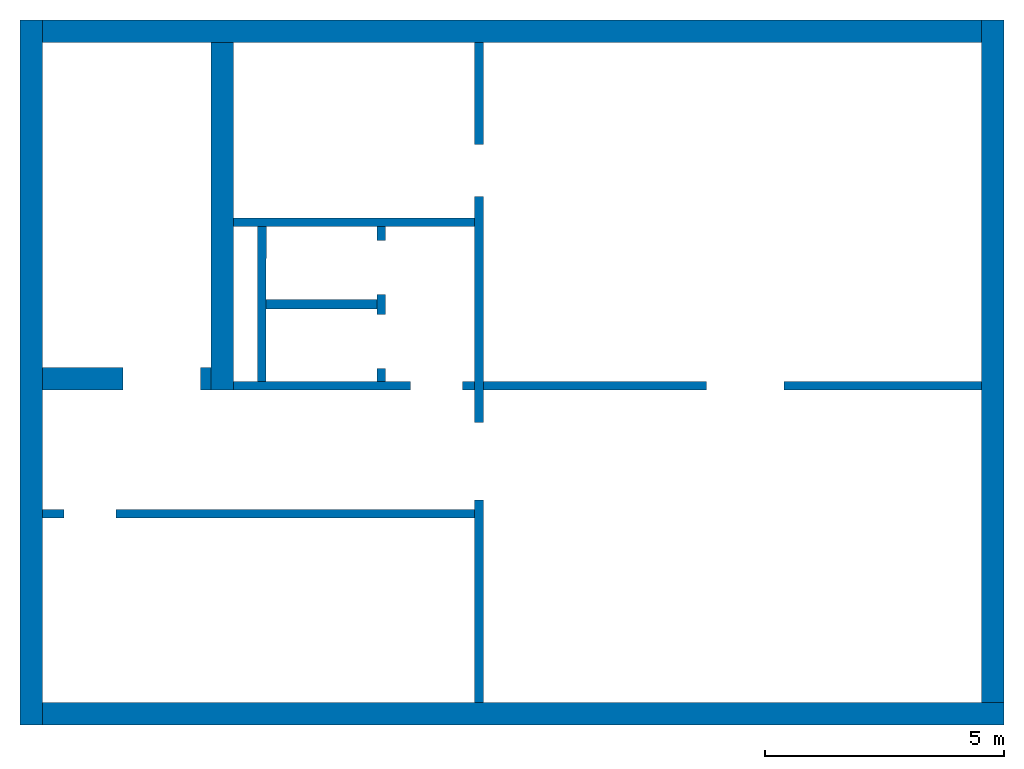
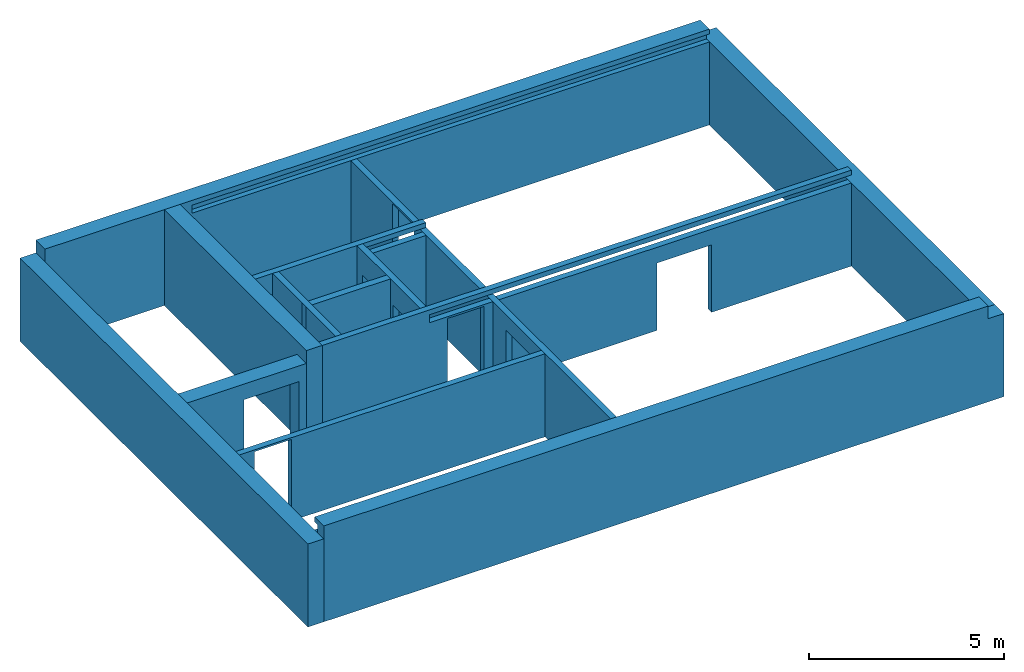
# One storey: 13 walls, 8 openings.
"""IFC4 building model written with IfcOpenShell, lengths in metres."""

from ifc_helpers import new_model, entity, si_unit, converted_unit, derived_unit, direction, frame, origin_with_axes, place, context, subcontext, project, spatial, polygons, material, type_object, element, save


model = new_model("IFC4")

# Units and contexts
model_context = context("Model", 3, precision=1e-05, world=origin_with_axes(), true_north=direction((0.0, 1.0)))
body_context = subcontext(model_context, "Body", "Model", "MODEL_VIEW")
ifc_project = project(units=[si_unit("LENGTHUNIT", "METRE"), si_unit("AREAUNIT", "SQUARE_METRE"), si_unit("VOLUMEUNIT", "CUBIC_METRE"), converted_unit("PLANEANGLEUNIT", "DEGREE", entity("IfcPlaneAngleMeasure", 0.0174532925199433), si_unit("PLANEANGLEUNIT", "RADIAN"), dimensions=[0, 0, 0, 0, 0, 0, 0]), converted_unit("TIMEUNIT", "Year", entity("IfcTimeMeasure", 31557600.0), si_unit("TIMEUNIT", "SECOND"), dimensions=[0, 0, 1, 0, 0, 0, 0]), si_unit("MASSUNIT", "GRAM", prefix="KILO"), si_unit("THERMODYNAMICTEMPERATUREUNIT", "DEGREE_CELSIUS"), si_unit("LUMINOUSINTENSITYUNIT", "LUMEN"), si_unit("ENERGYUNIT", "JOULE", prefix="MEGA"), derived_unit("THERMALCONDUCTANCEUNIT", [(si_unit("POWERUNIT", "WATT"), 1), (si_unit("LENGTHUNIT", "METRE"), -1), (si_unit("THERMODYNAMICTEMPERATUREUNIT", "KELVIN"), -1)]), derived_unit("SPECIFICHEATCAPACITYUNIT", [(si_unit("ENERGYUNIT", "JOULE"), 1), (si_unit("MASSUNIT", "GRAM", prefix="KILO"), -1), (si_unit("THERMODYNAMICTEMPERATUREUNIT", "KELVIN"), -1)]), derived_unit("MASSDENSITYUNIT", [(si_unit("MASSUNIT", "GRAM", prefix="KILO"), 1), (si_unit("VOLUMEUNIT", "CUBIC_METRE"), -1)])], contexts=[model_context])

# Site, building, storey
site_placement = place(None, origin_with_axes())
site = spatial("IfcSite", under=ifc_project, at=site_placement, CompositionType="ELEMENT")
building_placement = place(None, origin_with_axes())
building = spatial("IfcBuilding", under=site, at=building_placement, CompositionType="ELEMENT")
storey_placement = place(None, frame((0.0, 0.0, -3.0), z_axis=(0.0, 0.0, 1.0), x_axis=(1.0, 0.0, 0.0)))
storey = spatial("IfcBuildingStorey", under=building, at=storey_placement, Name="UG", CompositionType="ELEMENT", Elevation=-3.0)

# Wall, opening
ifc_material = material(Name="Stahlbeton")
wall_type_1 = type_object("IfcWallType", Name="Stahlbeton 180", PredefinedType="NOTDEFINED")
wall_1_placement = place(None, frame((33.505, 4.55499994546755, -3.0), z_axis=(0.0, 0.0, 1.0), x_axis=(-1.0, 0.0, 0.0)))
wall_1 = element("IfcWall", 1, at=wall_1_placement, inside=storey, type_object=wall_type_1, material=ifc_material, Name="Wand-003", PredefinedType="NOTDEFINED", context=body_context, shape_type="Tessellation", body=[
    polygons([(8.59699999999999, 0.0, 2.545), (8.59699999999999, 0.0, 0.0), (9.047, 0.0, 0.0), (9.047, 0.0, 2.6), (0.0, 0.0, 2.6), (0.0, 0.0, 0.0), (7.507, 0.0, 0.0), (7.507, 0.0, 2.545), (8.59699999999999, 0.18, 2.545), (8.59699999999999, 0.18, 0.0), (9.047, 0.18, 0.0), (9.047, 0.18, 2.6), (0.0, 0.180000000000001, 2.6), (0.0, 0.18, 0.0), (7.507, 0.18, 0.0), (7.507, 0.18, 2.545)], [[[1, 2, 3, 4, 5, 6, 7, 8]], [[2, 1, 9, 10]], [[2, 10, 11, 3]], [[11, 12, 4, 3]], [[12, 13, 5, 4]], [[14, 6, 5, 13]], [[15, 7, 6, 14]], [[8, 7, 15, 16]], [[1, 8, 16, 9]], [[16, 15, 14, 13, 12, 11, 10, 9]]], closed=True),
])
opening_1_placement = place(wall_1_placement, frame((8.052, 0.0, 0.0), z_axis=(0.0, 0.0, 1.0), x_axis=(1.0, 0.0, 0.0)))
element("IfcOpeningElement", 2, at=opening_1_placement, cuts=wall_1, context=body_context, identifier="Reference", shape_type="Tessellation", body=[
    polygons([(-0.544999999999998, -0.00100000000000033, 2.545), (-0.544999999999998, -0.00100000000000033, 0.0), (0.544999999999998, -0.00100000000000033, 0.0), (0.544999999999998, -0.00100000000000033, 2.545), (-0.544999999999998, 0.181, 2.545), (-0.544999999999998, 0.181, 0.0), (0.544999999999998, 0.181, 0.0), (0.544999999999998, 0.181, 2.545)], [[[1, 2, 3, 4]], [[5, 6, 2, 1]], [[6, 7, 3, 2]], [[7, 8, 4, 3]], [[8, 5, 1, 4]], [[7, 6, 5, 8]]], closed=True),
])

# Wall, openings
wall_2_placement = place(None, frame((27.988, 7.05499994546755, -3.0), z_axis=(0.0, 0.0, 1.0), x_axis=(1.0, 0.0, 0.0)))
wall_2 = element("IfcWall", 3, at=wall_2_placement, inside=storey, type_object=wall_type_1, material=ifc_material, Name="Wand-001", PredefinedType="NOTDEFINED", context=body_context, shape_type="Tessellation", body=[
    polygons([(10.370657642847, 0.18, 2.11), (10.370657642847, 0.18, 0.0), (5.69699999999999, 0.18, 0.0), (5.69699999999999, 0.180000000000002, 2.6), (8.20499999999999, 0.180000000000002, 2.6), (16.126, 0.180000000000001, 2.6), (16.126, 0.180000000000001, 0.0), (11.990657642847, 0.180000000000001, 0.0), (11.990657642847, 0.180000000000001, 2.11), (10.370657642847, 0.0, 2.11), (10.370657642847, 0.0, 0.0), (5.69699999999999, 0.0, 0.0), (5.69699999999999, 0.0, 2.6), (16.126, 0.0, 2.6), (16.126, 0.0, 0.0), (11.990657642847, 0.0, 0.0), (11.990657642847, 0.0, 2.11)], [[[1, 2, 3, 4, 5, 6, 7, 8, 9]], [[2, 1, 10, 11]], [[2, 11, 12, 3]], [[13, 4, 3, 12]], [[4, 13, 14, 6, 5]], [[6, 14, 15, 7]], [[16, 8, 7, 15]], [[9, 8, 16, 17]], [[1, 9, 17, 10]], [[17, 16, 15, 14, 13, 12, 11, 10]]], closed=True),
    polygons([(4.17199999999999, 0.18, 2.545), (4.17199999999999, 0.18, 0.0), (0.469999999999999, 0.18, 0.0), (0.469999999999999, 0.180000000000001, 3.0), (16.126, 0.180000000000001, 3.0), (16.126, 0.180000000000001, 2.85), (8.20499999999999, 0.180000000000002, 2.85), (5.69699999999999, 0.180000000000002, 2.85), (3.65000002908709, 0.18, 2.85), (3.65000002908709, 0.18, 2.6), (5.51699999999999, 0.18, 2.6), (5.51699999999999, 0.18, 0.0), (5.262, 0.18, 0.0), (5.262, 0.18, 2.545), (4.17199999999999, 1.29097926127031e-07, 2.545), (4.17199999999999, 0.0, 0.0), (0.469999999999999, 0.0, 0.0), (0.469999999999999, 0.0, 2.6), (0.469999999999999, 0.0, 3.0), (16.126, 0.0, 3.0), (16.126, 0.0, 2.85), (3.65000002908709, 1.29097926127031e-07, 2.85), (3.65000002908709, 1.29097926127031e-07, 2.6), (5.51699999999999, 0.0, 2.6), (5.51699999999999, 0.0, 0.0), (5.262, 0.0, 0.0), (5.262, 1.29097926127031e-07, 2.545)], [[[1, 2, 3, 4, 5, 6, 7, 8, 9, 10, 11, 12, 13, 14]], [[2, 1, 15, 16]], [[2, 16, 17, 3]], [[3, 17, 18, 19, 4]], [[5, 4, 19, 20]], [[21, 6, 5, 20]], [[6, 21, 22, 9, 8, 7]], [[10, 9, 22, 23]], [[24, 11, 10, 23]], [[11, 24, 25, 12]], [[26, 13, 12, 25]], [[14, 13, 26, 27]], [[1, 14, 27, 15]], [[27, 26, 25, 24, 23, 22, 21, 20, 19, 18, 17, 16, 15]]], closed=True),
])
opening_2_placement = place(wall_2_placement, frame((4.717, 0.0, 0.0), z_axis=(0.0, 0.0, 1.0), x_axis=(1.0, 0.0, 0.0)))
element("IfcOpeningElement", 4, at=opening_2_placement, cuts=wall_2, context=body_context, identifier="Reference", shape_type="Tessellation", body=[
    polygons([(-0.545000000000002, -0.00100000000000033, 2.545), (-0.545000000000002, -0.00100000000000033, 0.0), (0.545000000000002, -0.00100000000000033, 0.0), (0.545000000000002, -0.00100000000000033, 2.545), (-0.545000000000002, 0.181, 2.545), (-0.545000000000002, 0.181, 0.0), (0.545000000000002, 0.181, 0.0), (0.545000000000002, 0.181, 2.545)], [[[1, 2, 3, 4]], [[5, 6, 2, 1]], [[6, 7, 3, 2]], [[7, 8, 4, 3]], [[8, 5, 1, 4]], [[7, 6, 5, 8]]], closed=True),
])
opening_3_placement = place(wall_2_placement, frame((11.180657642847, 0.0, 0.0), z_axis=(0.0, 0.0, 1.0), x_axis=(1.0, 0.0, 0.0)))
element("IfcOpeningElement", 5, at=opening_3_placement, cuts=wall_2, context=body_context, identifier="Reference", shape_type="Tessellation", body=[
    polygons([(0.810000000000002, 0.181000000000002, 2.11), (0.810000000000002, 0.181000000000002, 0.0), (-0.810000000000002, 0.181000000000002, 0.0), (-0.810000000000002, 0.181000000000003, 2.11), (0.810000000000002, -0.00100000000000478, 2.11), (0.810000000000002, -0.00100000000000478, 0.0), (-0.810000000000002, -0.00100000000000478, 0.0), (-0.810000000000002, -0.00100000000000389, 2.11)], [[[1, 2, 3, 4]], [[5, 6, 2, 1]], [[6, 7, 3, 2]], [[7, 8, 4, 3]], [[8, 5, 1, 4]], [[7, 6, 5, 8]]], closed=True),
])

# Wall
wall_3_placement = place(None, frame((29.1377045594425, 7.05499994546755, -3.0), z_axis=(0.0, 0.0, 1.0), x_axis=(0.00164133421967425, 0.999998653010083, 0.0)))
element("IfcWall", 6, at=wall_3_placement, inside=storey, type_object=wall_type_1, material=ifc_material, Name="Wand-001", PredefinedType="NOTDEFINED", context=body_context, shape_type="Tessellation", body=[
    polygons([(0.179704801901014, 0.18, 0.0), (3.41970916615423, 0.180000000000007, 0.0), (3.42000460671172, 0.0, 0.0), (0.180000242458512, 0.0, 0.0), (0.179704801901014, 0.18, 3.0), (3.41970916615423, 0.180000000000007, 3.0), (3.42000460671172, 0.0, 3.0), (0.180000242458512, 0.0, 3.0)], [[[1, 2, 3, 4]], [[5, 6, 2, 1]], [[7, 3, 2, 6]], [[4, 3, 7, 8]], [[8, 5, 1, 4]], [[8, 7, 6, 5]]], closed=True),
])

# Wall, openings
wall_4_placement = place(None, frame((33.505, 14.3318657372406, -3.0), z_axis=(0.0, 0.0, 1.0), x_axis=(0.0, -1.0, 0.0)))
wall_4 = element("IfcWall", 7, at=wall_4_placement, inside=storey, type_object=wall_type_1, material=ifc_material, Name="Wand-001", PredefinedType="NOTDEFINED", context=body_context, shape_type="Tessellation", body=[
    polygons([(3.22686579177299, 0.18, 0.0), (3.22686579177299, 0.18, 2.545), (2.13686579177299, 0.18, 2.545), (2.13686579177299, 0.18, 0.0), (0.0, 0.18, 0.0), (0.0, 0.18, 2.6), (13.8118657372406, 0.18, 2.6), (13.8118657372406, 0.18, 0.0), (9.57686579177299, 0.18, 0.0), (9.57686579177299, 0.18, 2.11), (7.95686579177299, 0.18, 2.11), (7.95686579177299, 0.18, 0.0), (3.22686579177299, 0.0, 0.0), (3.22686579177299, 0.0, 2.545), (2.13686579177299, 0.0, 2.545), (2.13686579177299, 0.0, 0.0), (0.0, 0.0, 0.0), (0.0, 0.0, 2.6), (13.8118657372406, 0.0, 2.6), (13.8118657372406, 0.0, 0.0), (9.57686579177299, 0.0, 0.0), (9.57686579177299, 0.0, 2.11), (7.95686579177299, 0.0, 2.11), (7.95686579177299, 0.0, 0.0)], [[[1, 2, 3, 4, 5, 6, 7, 8, 9, 10, 11, 12]], [[2, 1, 13, 14]], [[3, 2, 14, 15]], [[4, 3, 15, 16]], [[4, 16, 17, 5]], [[17, 18, 6, 5]], [[6, 18, 19, 7]], [[7, 19, 20, 8]], [[9, 8, 20, 21]], [[9, 21, 22, 10]], [[10, 22, 23, 11]], [[11, 23, 24, 12]], [[13, 1, 12, 24]], [[14, 13, 24, 23, 22, 21, 20, 19, 18, 17, 16, 15]]], closed=True),
])
opening_4_placement = place(wall_4_placement, frame((2.68186579177299, 0.0, 0.0), z_axis=(0.0, 0.0, 1.0), x_axis=(1.0, 0.0, 0.0)))
element("IfcOpeningElement", 8, at=opening_4_placement, cuts=wall_4, context=body_context, identifier="Reference", shape_type="Tessellation", body=[
    polygons([(-0.545, -0.000999999999997669, 2.545), (-0.545, -0.000999999999997669, 0.0), (0.545, -0.000999999999997669, 0.0), (0.545, -0.000999999999997669, 2.545), (-0.545, 0.180999999999997, 2.545), (-0.545, 0.180999999999997, 0.0), (0.545, 0.180999999999997, 0.0), (0.545, 0.180999999999997, 2.545)], [[[1, 2, 3, 4]], [[5, 6, 2, 1]], [[6, 7, 3, 2]], [[7, 8, 4, 3]], [[8, 5, 1, 4]], [[7, 6, 5, 8]]], closed=True),
])
opening_5_placement = place(wall_4_placement, frame((8.76686579177299, 0.0, 0.0), z_axis=(0.0, 0.0, 1.0), x_axis=(1.0, 0.0, 0.0)))
element("IfcOpeningElement", 9, at=opening_5_placement, cuts=wall_4, context=body_context, identifier="Reference", shape_type="Tessellation", body=[
    polygons([(0.81, 0.180999999999997, 2.11), (0.81, 0.180999999999997, 0.0), (-0.81, 0.180999999999997, 0.0), (-0.81, 0.180999999999997, 2.11), (0.81, -0.000999999999997669, 2.11), (0.81, -0.000999999999997669, 0.0), (-0.81, -0.000999999999997669, 0.0), (-0.81, -0.000999999999997669, 2.11)], [[[1, 2, 3, 4]], [[5, 6, 2, 1]], [[6, 7, 3, 2]], [[7, 8, 4, 3]], [[8, 5, 1, 4]], [[7, 6, 5, 8]]], closed=True),
])

wall_5_placement = place(None, frame((31.638, 7.05499994546755, -3.0), z_axis=(0.0, 0.0, 1.0), x_axis=(0.0, 1.0, 0.0)))
wall_5 = element("IfcWall", 10, at=wall_5_placement, inside=storey, type_object=wall_type_1, material=ifc_material, Name="Wand-002", PredefinedType="NOTDEFINED", context=body_context, shape_type="Tessellation", body=[
    polygons([(2.0, 0.0, 0.0), (2.0, 0.0, 2.25), (3.13, 0.0, 2.25), (3.13, 0.0, 0.0), (3.42, 0.0, 0.0), (3.42, 0.0, 3.0), (0.179999999999999, 0.0, 3.0), (0.179999999999999, 0.0, 0.0), (0.450000000000002, 0.0, 0.0), (0.450000000000002, 0.0, 2.25), (1.58, 0.0, 2.25), (1.58, 0.0, 0.0), (2.0, 0.179999999999996, 0.0), (2.0, 0.179999999999996, 2.25), (3.13, 0.179999999999996, 2.25), (3.13, 0.179999999999996, 0.0), (3.42, 0.179999999999996, 0.0), (3.42, 0.179999999999996, 3.0), (0.179999999999999, 0.18, 3.0), (0.179999999999999, 0.18, 0.0), (0.450000000000002, 0.18, 0.0), (0.450000000000002, 0.18, 2.25), (1.58, 0.18, 2.25), (1.58, 0.18, 0.0)], [[[1, 2, 3, 4, 5, 6, 7, 8, 9, 10, 11, 12]], [[2, 1, 13, 14]], [[3, 2, 14, 15]], [[4, 3, 15, 16]], [[4, 16, 17, 5]], [[18, 6, 5, 17]], [[19, 7, 6, 18]], [[8, 7, 19, 20]], [[9, 8, 20, 21]], [[9, 21, 22, 10]], [[10, 22, 23, 11]], [[11, 23, 24, 12]], [[13, 1, 12, 24]], [[14, 13, 24, 23, 22, 21, 20, 19, 18, 17, 16, 15]]], closed=True),
])
opening_6_placement = place(wall_5_placement, frame((2.565, 0.0, 0.0), z_axis=(0.0, 0.0, 1.0), x_axis=(1.0, 0.0, 0.0)))
element("IfcOpeningElement", 11, at=opening_6_placement, cuts=wall_5, context=body_context, identifier="Reference", shape_type="Tessellation", body=[
    polygons([(-0.565, -0.00100000000000478, 2.25), (-0.565, -0.00100000000000478, 0.0), (0.565, -0.00100000000000478, 0.0), (0.565, -0.00100000000000478, 2.25), (-0.564999999999998, 0.181000000000001, 2.25), (-0.564999999999998, 0.181000000000001, 0.0), (0.565000000000001, 0.181000000000001, 0.0), (0.565000000000001, 0.181000000000001, 2.25)], [[[1, 2, 3, 4]], [[5, 6, 2, 1]], [[6, 7, 3, 2]], [[7, 8, 4, 3]], [[8, 5, 1, 4]], [[7, 6, 5, 8]]], closed=True),
])
opening_7_placement = place(wall_5_placement, frame((1.015, 0.0, 0.0), z_axis=(0.0, 0.0, 1.0), x_axis=(1.0, 0.0, 0.0)))
element("IfcOpeningElement", 12, at=opening_7_placement, cuts=wall_5, context=body_context, identifier="Reference", shape_type="Tessellation", body=[
    polygons([(-0.565, -0.00100000000000122, 2.25), (-0.565, -0.00100000000000122, 0.0), (0.565, -0.00100000000000122, 0.0), (0.565, -0.00100000000000122, 2.25), (-0.565, 0.181000000000004, 2.25), (-0.565, 0.181000000000004, 0.0), (0.565000000000001, 0.181000000000004, 0.0), (0.565000000000001, 0.181000000000004, 2.25)], [[[1, 2, 3, 4]], [[5, 6, 2, 1]], [[6, 7, 3, 2]], [[7, 8, 4, 3]], [[8, 5, 1, 4]], [[7, 6, 5, 8]]], closed=True),
])

# Walls
wall_6_placement = place(None, frame((33.505, 10.6549999454676, -3.0), z_axis=(0.0, 0.0, 1.0), x_axis=(-1.0, 0.0, 0.0)))
element("IfcWall", 13, at=wall_6_placement, inside=storey, type_object=wall_type_1, material=ifc_material, Name="Wand-003", PredefinedType="NOTDEFINED", context=body_context, shape_type="Tessellation", body=[
    polygons([(0.0, 0.18, 3.0), (0.0, 0.180000000000001, 2.85), (0.0, 0.0, 2.85), (0.0, 0.0, 3.0), (1.8669999709129, 0.18, 2.6), (1.8669999709129, 0.18, 2.85), (5.04699999999999, 0.18, 3.0), (5.04699999999999, 0.18, 0.0), (0.0, 0.18, 0.0), (0.0, 0.180000000000003, 2.6), (1.8669999709129, -8.86263311627999e-08, 2.85), (1.8669999709129, -8.86263311627999e-08, 2.6), (0.0, 0.0, 2.6), (0.0, 0.0, 0.0), (5.04699999999999, 0.0, 0.0), (5.04699999999999, 0.0, 3.0)], [[[1, 2, 3, 4]], [[5, 6, 2, 1, 7, 8, 9, 10]], [[6, 11, 3, 2]], [[11, 12, 13, 14, 15, 16, 4, 3]], [[4, 16, 7, 1]], [[5, 12, 11, 6]], [[8, 7, 16, 15]], [[8, 15, 14, 9]], [[14, 13, 10, 9]], [[5, 10, 13, 12]]], closed=True),
])
wall_type_2 = type_object("IfcWallType", Name="Stahlbeton 470", PredefinedType="NOTDEFINED")
wall_7_placement = place(None, frame((44.114, 14.3318657372406, -3.0), z_axis=(0.0, 0.0, 1.0), x_axis=(-1.0, 0.0, 0.0)))
element("IfcWall", 14, at=wall_7_placement, inside=storey, type_object=wall_type_2, material=ifc_material, Name="Wand-004", PredefinedType="NOTDEFINED", context=body_context, shape_type="Tessellation", body=[
    polygons([(0.0, 0.0, 2.85), (0.0, -0.151134016234401, 2.85), (0.0, -0.151134016234401, 2.6), (0.0, -0.470000000000001, 2.6), (0.0, -0.470000000000001, 3.0), (0.0, 0.0, 3.0), (15.306, -0.151134016234401, 2.85), (15.306, 0.0, 2.85), (15.306, -0.151134016234401, 2.6), (0.0, 0.0, 2.6), (0.0, 0.0, 0.0), (0.0, -0.470000000000001, 0.0), (19.656, -0.470000000000002, 3.0), (19.656, -0.470000000000001, 0.0), (19.656, -0.470000000000001, 2.6), (19.656, -0.470000000000002, 2.85), (19.656, 0.0, 3.0), (15.306, 0.0, 2.6), (19.656, 0.0, 2.85), (19.656, 0.0, 2.6), (19.656, 0.0, 0.0)], [[[1, 2, 3, 4, 5, 6]], [[7, 2, 1, 8]], [[9, 3, 2, 7]], [[4, 3, 10, 11, 12]], [[13, 5, 4, 12, 14, 15, 16]], [[6, 5, 13, 17]], [[18, 8, 1, 6, 17, 19, 20, 21, 11, 10]], [[7, 8, 18, 9]], [[18, 10, 3, 9]], [[21, 14, 12, 11]], [[14, 21, 20, 15]], [[19, 16, 15, 20]], [[16, 19, 17, 13]]], closed=True),
])
wall_8_placement = place(None, frame((24.458, 14.3318657372406, -3.0), z_axis=(0.0, 0.0, 1.0), x_axis=(0.0, -1.0, 0.0)))
element("IfcWall", 15, at=wall_8_placement, inside=storey, type_object=wall_type_2, material=ifc_material, Name="Wand-001", PredefinedType="NOTDEFINED", context=body_context, shape_type="Tessellation", body=[
    polygons([(14.2818657372405, -0.469999999999999, 2.6), (14.2818657372405, 0.0, 2.6), (-0.470000000000001, 0.0, 2.6), (-0.469999999999999, -0.469999999999999, 2.6), (14.2818657372405, -0.469999999999999, 0.0), (14.2818657372405, 0.0, 0.0), (-0.470000000000001, 0.0, 0.0), (-0.469999999999999, -0.469999999999999, 0.0)], [[[1, 2, 3, 4]], [[2, 1, 5, 6]], [[2, 6, 7, 3]], [[8, 4, 3, 7]], [[5, 1, 4, 8]], [[6, 5, 8, 7]]], closed=True),
])
wall_9_placement = place(None, frame((27.988, 14.3318657372406, -3.0), z_axis=(0.0, 0.0, 1.0), x_axis=(0.0, -1.0, 0.0)))
element("IfcWall", 16, at=wall_9_placement, inside=storey, type_object=wall_type_2, material=ifc_material, Name="Wand-003", PredefinedType="NOTDEFINED", context=body_context, shape_type="Tessellation", body=[
    polygons([(7.276865791773, 0.469999999999999, 3.0), (7.276865791773, 0.0, 3.0), (7.27686579177299, 0.0, 2.6), (7.27686579177299, 0.469999999999999, 2.6), (0.0, 0.469999999999999, 3.0), (0.0, 0.0, 3.0), (0.0, 0.0, 0.0), (7.27686579177299, 0.0, 0.0), (7.27686579177299, 0.469999999999999, 0.0), (0.0, 0.469999999999999, 0.0)], [[[1, 2, 3, 4]], [[5, 6, 2, 1]], [[6, 7, 8, 3, 2]], [[3, 8, 9, 4]], [[5, 1, 4, 9, 10]], [[6, 5, 10, 7]], [[7, 10, 9, 8]]], closed=True),
])
wall_10_placement = place(None, frame((44.114, 0.52, -3.0), z_axis=(0.0, 0.0, 1.0), x_axis=(0.0, 1.0, 0.0)))
element("IfcWall", 17, at=wall_10_placement, inside=storey, type_object=wall_type_2, material=ifc_material, Name="Wand-003", PredefinedType="NOTDEFINED", context=body_context, shape_type="Tessellation", body=[
    polygons([(14.2818657372405, -0.469999999999999, 2.6), (14.2818657372405, 0.0, 2.6), (0.0, 0.0, 2.6), (0.0, -0.469999999999999, 2.6), (14.2818657372405, -0.469999999999999, 0.0), (14.2818657372405, 0.0, 0.0), (0.0, 0.0, 0.0), (0.0, -0.469999999999999, 0.0)], [[[1, 2, 3, 4]], [[2, 1, 5, 6]], [[2, 6, 7, 3]], [[8, 4, 3, 7]], [[5, 1, 4, 8]], [[6, 5, 8, 7]]], closed=True),
])

# Wall, opening
wall_11_placement = place(None, frame((27.988, 7.05499994546755, -3.0), z_axis=(0.0, 0.0, 1.0), x_axis=(-1.0, 0.0, 0.0)))
wall_11 = element("IfcWall", 18, at=wall_11_placement, inside=storey, type_object=wall_type_2, material=ifc_material, Name="Wand-001", PredefinedType="NOTDEFINED", context=body_context, shape_type="Tessellation", body=[
    polygons([(1.84, -0.470000000000001, 2.11), (1.84, -0.47, 0.0), (3.53, -0.470000000000001, 0.0), (3.53, -0.47, 2.6), (0.0, -0.47, 2.6), (0.0, -0.47, 0.0), (0.219999999999999, -0.47, 0.0), (0.219999999999999, -0.470000000000001, 2.11), (1.84, 0.0, 2.11), (1.84, 0.0, 0.0), (3.53, 0.0, 0.0), (3.53, 0.0, 2.6), (0.0, 0.0, 2.6), (0.0, 0.0, 0.0), (0.219999999999999, 0.0, 0.0), (0.219999999999999, 0.0, 2.11)], [[[1, 2, 3, 4, 5, 6, 7, 8]], [[2, 1, 9, 10]], [[2, 10, 11, 3]], [[4, 3, 11, 12]], [[12, 13, 5, 4]], [[5, 13, 14, 6]], [[15, 7, 6, 14]], [[8, 7, 15, 16]], [[1, 8, 16, 9]], [[16, 15, 14, 13, 12, 11, 10, 9]]], closed=True),
])
opening_8_placement = place(wall_11_placement, frame((1.03, 0.0, 0.0), z_axis=(0.0, 0.0, 1.0), x_axis=(1.0, 0.0, 0.0)))
element("IfcOpeningElement", 19, at=opening_8_placement, cuts=wall_11, context=body_context, identifier="Reference", shape_type="Tessellation", body=[
    polygons([(-0.809999999999999, -0.471, 2.11), (-0.809999999999999, -0.471, 0.0), (0.809999999999999, -0.471, 0.0), (0.809999999999999, -0.471, 2.11), (-0.809999999999999, 0.00100000000000033, 2.11), (-0.809999999999999, 0.00100000000000033, 0.0), (0.809999999999999, 0.00100000000000033, 0.0), (0.809999999999999, 0.00100000000000033, 2.11)], [[[1, 2, 3, 4]], [[5, 6, 2, 1]], [[6, 7, 3, 2]], [[7, 8, 4, 3]], [[8, 5, 1, 4]], [[7, 6, 5, 8]]], closed=True),
])

# Walls
wall_12_placement = place(None, frame((24.458, 0.52, -3.0), z_axis=(0.0, 0.0, 1.0), x_axis=(1.0, 0.0, 0.0)))
element("IfcWall", 20, at=wall_12_placement, inside=storey, type_object=wall_type_2, material=ifc_material, Name="Wand-002", PredefinedType="NOTDEFINED", context=body_context, shape_type="Tessellation", body=[
    polygons([(19.656, -0.469999999999999, 2.6), (19.656, -0.156999999999999, 2.6), (19.656, -0.156999999999999, 2.85), (19.656, 0.0, 2.85), (19.656, 0.0, 3.0), (19.656, -0.469999999999999, 3.0), (20.126, 0.0, 2.6), (19.656, 0.0, 2.6), (20.126, -0.469999999999999, 2.6), (0.0, -0.156999999999999, 2.85), (0.0, -0.156999999999999, 2.6), (0.0, 0.0, 2.85), (0.0, 0.0, 3.0), (0.0, -0.47, 3.0), (0.0, -0.47, 2.6), (0.0, -0.47, 0.0), (20.126, -0.469999999999999, 0.0), (0.0, 0.0, 0.0), (0.0, 0.0, 2.6), (20.126, 0.0, 0.0)], [[[1, 2, 3, 4, 5, 6]], [[7, 8, 2, 1, 9]], [[10, 3, 2, 11]], [[10, 12, 4, 3]], [[5, 4, 12, 13]], [[5, 13, 14, 6]], [[6, 14, 15, 16, 17, 9, 1]], [[18, 19, 8, 7, 20]], [[11, 2, 8, 19]], [[9, 17, 20, 7]], [[12, 10, 11, 15, 14, 13]], [[15, 11, 19, 18, 16]], [[20, 17, 16, 18]]], closed=True),
])
wall_type_3 = type_object("IfcWallType", Name="Stahlbeton 200", PredefinedType="NOTDEFINED")
wall_13_placement = place(None, frame((28.958, 8.85499994546755, -3.0), z_axis=(0.0, 0.0, 1.0), x_axis=(1.0, 0.0, 0.0)))
element("IfcWall", 21, at=wall_13_placement, inside=storey, type_object=wall_type_3, material=ifc_material, Name="Wand-001", PredefinedType="NOTDEFINED", context=body_context, shape_type="Tessellation", body=[
    polygons([(0.00282285620201961, 0.0999999999999996, 0.0), (0.00249458891590848, -0.0999999999999996, 0.0), (0.0, -0.0999999999999996, 0.0), (0.0, 0.0999999999999996, 0.0), (0.00282285620201961, 0.0999999999999996, 3.0), (0.00249458891590848, -0.0999999999999996, 3.0), (0.0, -0.0999999999999996, 3.0), (0.0, 0.0999999999999996, 3.0)], [[[1, 2, 3, 4]], [[2, 1, 5, 6]], [[2, 6, 7, 3]], [[8, 4, 3, 7]], [[5, 1, 4, 8]], [[6, 5, 8, 7]]], closed=True),
    polygons([(2.5, 0.0999999999999996, 0.0), (2.5, -0.0999999999999996, 0.0), (0.18249483137442, -0.0999999999999996, 0.0), (0.182823098660531, 0.0999999999999996, 0.0), (2.5, 0.0999999999999996, 3.0), (2.5, -0.0999999999999996, 3.0), (0.18249483137442, -0.0999999999999996, 3.0), (0.182823098660531, 0.0999999999999996, 3.0)], [[[1, 2, 3, 4]], [[2, 1, 5, 6]], [[2, 6, 7, 3]], [[8, 4, 3, 7]], [[5, 1, 4, 8]], [[6, 5, 8, 7]]], closed=True),
])

save(model, "model.ifc")
